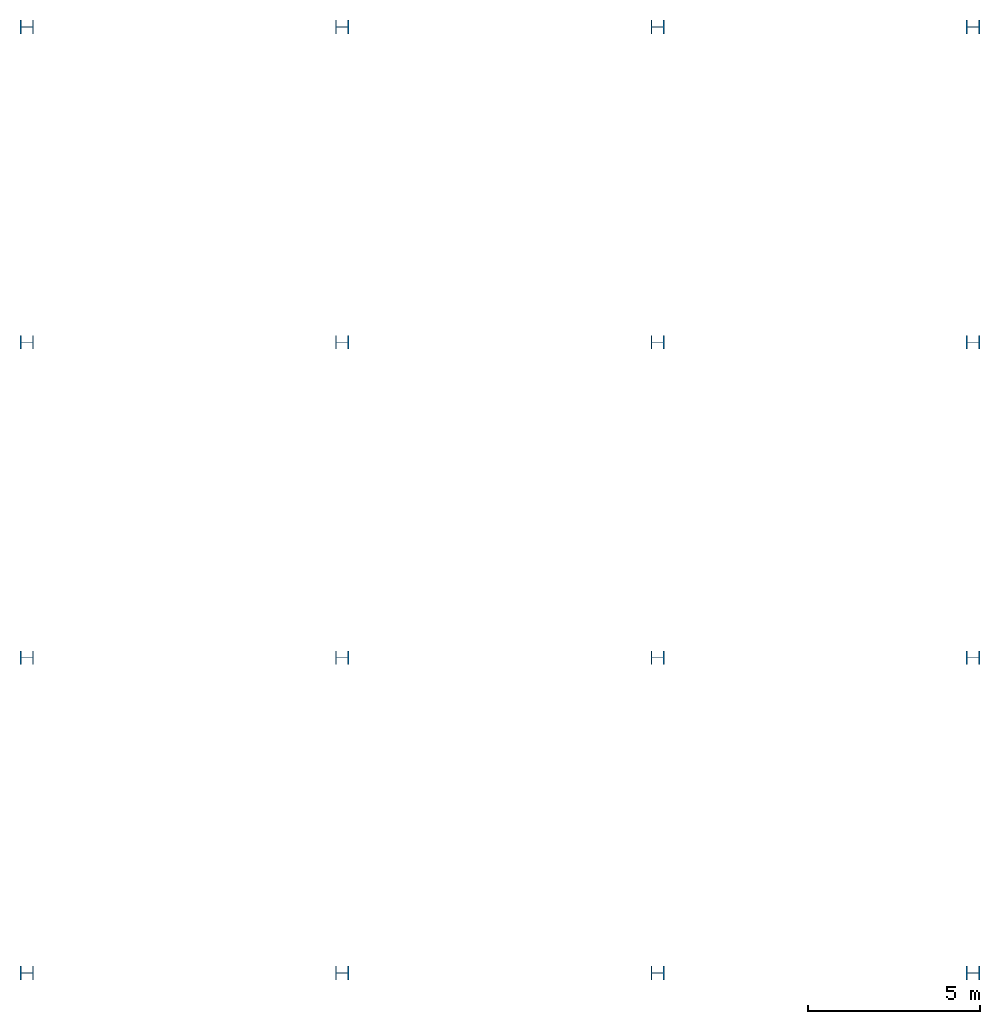
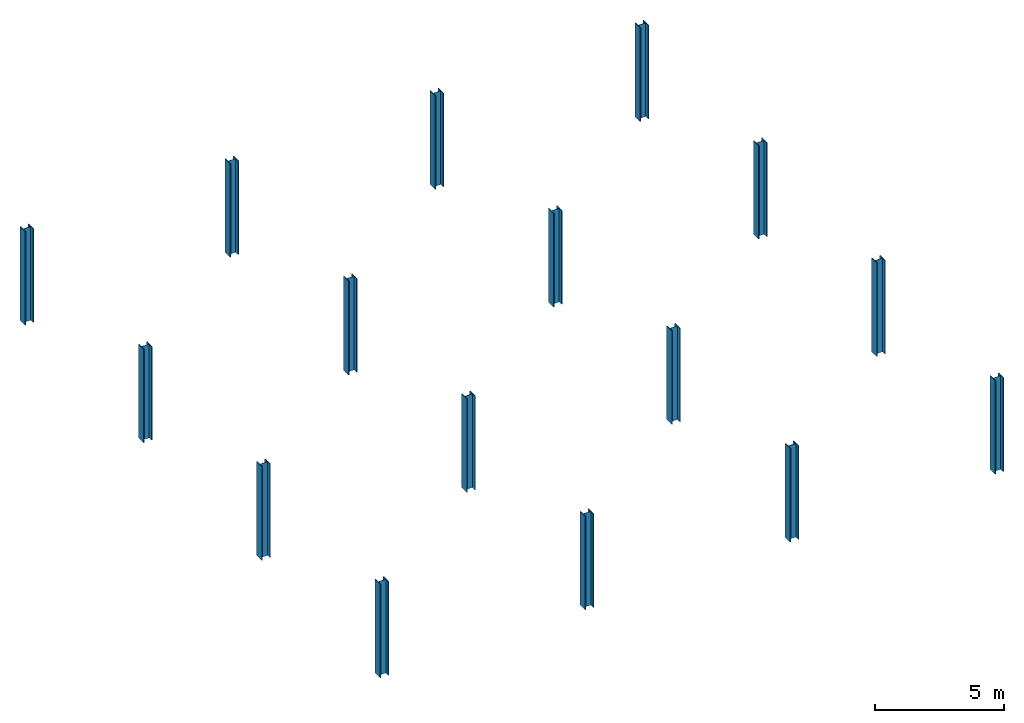
# One storey: 16 columns.
"""IFC2X3 building model written with IfcOpenShell, lengths in inches."""

from ifc_helpers import new_model, entity, si_unit, converted_unit, derived_unit, frame, origin_with_axes, origin_2d_with_axis, place, context, project, spatial, i_section, extrude, material, element, save


model = new_model("IFC2X3")

# Units and contexts
model_context = context("Model", 3, world=origin_with_axes())
ifc_project = project(units=[converted_unit("LENGTHUNIT", "INCH", entity("IfcLengthMeasure", 25.4), si_unit("LENGTHUNIT", "METRE", prefix="MILLI"), dimensions=[1, 0, 0, 0, 0, 0, 0]), converted_unit("AREAUNIT", "SQUARE INCH", entity("IfcAreaMeasure", 645.16), si_unit("AREAUNIT", "SQUARE_METRE", prefix="MICRO"), dimensions=[2, 0, 0, 0, 0, 0, 0]), converted_unit("VOLUMEUNIT", "CUBIC INCH", entity("IfcVolumeMeasure", 16387.064), si_unit("VOLUMEUNIT", "CUBIC_METRE", prefix="NANO"), dimensions=[3, 0, 0, 0, 0, 0, 0]), derived_unit("SECTIONMODULUSUNIT", [(converted_unit("LENGTHUNIT", "INCH", entity("IfcLengthMeasure", 25.4), si_unit("LENGTHUNIT", "METRE", prefix="MILLI"), dimensions=[1, 0, 0, 0, 0, 0, 0]), 3)]), derived_unit("MOMENTOFINERTIAUNIT", [(converted_unit("LENGTHUNIT", "INCH", entity("IfcLengthMeasure", 25.4), si_unit("LENGTHUNIT", "METRE", prefix="MILLI"), dimensions=[1, 0, 0, 0, 0, 0, 0]), 4)]), si_unit("PLANEANGLEUNIT", "RADIAN"), si_unit("TIMEUNIT", "SECOND"), converted_unit("FORCEUNIT", "LBF", entity("IfcForceMeasure", 4.448222), si_unit("FORCEUNIT", "NEWTON"), dimensions=[1, 1, -2, 0, 0, 0, 0]), derived_unit("TORQUEUNIT", [(converted_unit("LENGTHUNIT", "INCH", entity("IfcLengthMeasure", 25.4), si_unit("LENGTHUNIT", "METRE", prefix="MILLI"), dimensions=[1, 0, 0, 0, 0, 0, 0]), 1), (converted_unit("FORCEUNIT", "LBF", entity("IfcForceMeasure", 4.448222), si_unit("FORCEUNIT", "NEWTON"), dimensions=[1, 1, -2, 0, 0, 0, 0]), 1)]), converted_unit("PRESSUREUNIT", "PSI", entity("IfcPressureMeasure", 6894.7579), si_unit("PRESSUREUNIT", "PASCAL"), dimensions=[-1, 1, -2, 0, 0, 0, 0]), derived_unit("LINEARFORCEUNIT", [(converted_unit("LENGTHUNIT", "INCH", entity("IfcLengthMeasure", 25.4), si_unit("LENGTHUNIT", "METRE", prefix="MILLI"), dimensions=[1, 0, 0, 0, 0, 0, 0]), -1), (converted_unit("FORCEUNIT", "LBF", entity("IfcForceMeasure", 4.448222), si_unit("FORCEUNIT", "NEWTON"), dimensions=[1, 1, -2, 0, 0, 0, 0]), 1)]), derived_unit("PLANARFORCEUNIT", [(converted_unit("LENGTHUNIT", "INCH", entity("IfcLengthMeasure", 25.4), si_unit("LENGTHUNIT", "METRE", prefix="MILLI"), dimensions=[1, 0, 0, 0, 0, 0, 0]), -2), (converted_unit("FORCEUNIT", "LBF", entity("IfcForceMeasure", 4.448222), si_unit("FORCEUNIT", "NEWTON"), dimensions=[1, 1, -2, 0, 0, 0, 0]), 1)]), derived_unit("LINEARMOMENTUNIT", [(converted_unit("FORCEUNIT", "LBF", entity("IfcForceMeasure", 4.448222), si_unit("FORCEUNIT", "NEWTON"), dimensions=[1, 1, -2, 0, 0, 0, 0]), 1), (converted_unit("LENGTHUNIT", "INCH", entity("IfcLengthMeasure", 25.4), si_unit("LENGTHUNIT", "METRE", prefix="MILLI"), dimensions=[1, 0, 0, 0, 0, 0, 0]), 1), (converted_unit("LENGTHUNIT", "INCH", entity("IfcLengthMeasure", 25.4), si_unit("LENGTHUNIT", "METRE", prefix="MILLI"), dimensions=[1, 0, 0, 0, 0, 0, 0]), -1)]), derived_unit("SHEARMODULUSUNIT", [(converted_unit("LENGTHUNIT", "INCH", entity("IfcLengthMeasure", 25.4), si_unit("LENGTHUNIT", "METRE", prefix="MILLI"), dimensions=[1, 0, 0, 0, 0, 0, 0]), -2), (converted_unit("FORCEUNIT", "LBF", entity("IfcForceMeasure", 4.448222), si_unit("FORCEUNIT", "NEWTON"), dimensions=[1, 1, -2, 0, 0, 0, 0]), 1)]), derived_unit("MODULUSOFELASTICITYUNIT", [(converted_unit("LENGTHUNIT", "INCH", entity("IfcLengthMeasure", 25.4), si_unit("LENGTHUNIT", "METRE", prefix="MILLI"), dimensions=[1, 0, 0, 0, 0, 0, 0]), -2), (converted_unit("FORCEUNIT", "LBF", entity("IfcForceMeasure", 4.448222), si_unit("FORCEUNIT", "NEWTON"), dimensions=[1, 1, -2, 0, 0, 0, 0]), 1)]), converted_unit("THERMODYNAMICTEMPERATUREUNIT", "FAHRENHEIT", entity("IfcThermodynamicTemperatureMeasure", 0.55555556), si_unit("THERMODYNAMICTEMPERATUREUNIT", "KELVIN"), dimensions=[0, 0, 0, 0, 1, 0, 0]), derived_unit("THERMALEXPANSIONCOEFFICIENTUNIT", [(converted_unit("THERMODYNAMICTEMPERATUREUNIT", "FAHRENHEIT", entity("IfcThermodynamicTemperatureMeasure", 0.55555556), si_unit("THERMODYNAMICTEMPERATUREUNIT", "KELVIN"), dimensions=[0, 0, 0, 0, 1, 0, 0]), -1)])], contexts=[model_context])

# Site, building, storey
site = spatial("IfcSite", under=ifc_project, CompositionType="ELEMENT")
building = spatial("IfcBuilding", under=site, Name="Default Building", CompositionType="ELEMENT")
storey = spatial("IfcBuildingStorey", under=building, Name="BASE LEVEL", CompositionType="ELEMENT", Elevation=0.0)

# Columns
ifc_material = material(Name="A992Fy50")
for number, where, z_axis, x_axis, name in (
    (1, (0.0, 0.0, 0.0), (0.0, 0.0, 1.0), (0.0, -1.0, 0.0), "1"),
    (2, (0.0, 360.0, 0.0), (0.0, 0.0, 1.0), (0.0, -1.0, 0.0), "2"),
    (3, (0.0, 720.0, 0.0), (0.0, 0.0, 1.0), (0.0, -1.0, 0.0), "3"),
    (4, (0.0, 1080.0, 0.0), (0.0, 0.0, 1.0), (0.0, -1.0, 0.0), "4"),
    (5, (360.0, 0.0, 0.0), (0.0, 0.0, 1.0), (0.0, -1.0, 0.0), "5"),
    (6, (360.0, 360.0, 0.0), (0.0, 0.0, 1.0), (0.0, -1.0, 0.0), "6"),
    (7, (360.0, 720.0, 0.0), (0.0, 0.0, 1.0), (0.0, -1.0, 0.0), "7"),
    (8, (360.0, 1080.0, 0.0), (0.0, 0.0, 1.0), (0.0, -1.0, 0.0), "8"),
    (9, (720.0, 0.0, 0.0), (0.0, 0.0, 1.0), (0.0, -1.0, 0.0), "9"),
    (10, (720.0, 360.0, 0.0), (0.0, 0.0, 1.0), (0.0, -1.0, 0.0), "10"),
    (11, (720.0, 720.0, 0.0), (0.0, 0.0, 1.0), (0.0, -1.0, 0.0), "11"),
    (12, (720.0, 1080.0, 0.0), (0.0, 0.0, 1.0), (0.0, -1.0, 0.0), "12"),
    (13, (1080.0, 0.0, 0.0), (0.0, 0.0, 1.0), (0.0, -1.0, 0.0), "13"),
    (14, (1080.0, 360.0, 0.0), (0.0, 0.0, 1.0), (0.0, -1.0, 0.0), "14"),
    (15, (1080.0, 720.0, 0.0), (0.0, 0.0, 1.0), (0.0, -1.0, 0.0), "15"),
    (16, (1080.0, 1080.0, 0.0), (0.0, 0.0, 1.0), (0.0, -1.0, 0.0), "16"),
):
    element("IfcColumn", number, at=place(None, frame(where, z_axis=z_axis, x_axis=x_axis)), inside=storey, material=ifc_material, Name=name, context=model_context, shape_type="SweptSolid", body=[
        extrude(i_section(OverallWidth=15.7, OverallDepth=15.5, WebThickness=0.89, FlangeThickness=1.44, at=origin_2d_with_axis()), origin_with_axes(), (0.0, 0.0, 1.0), 173.8),
    ])

save(model, "model.ifc")
